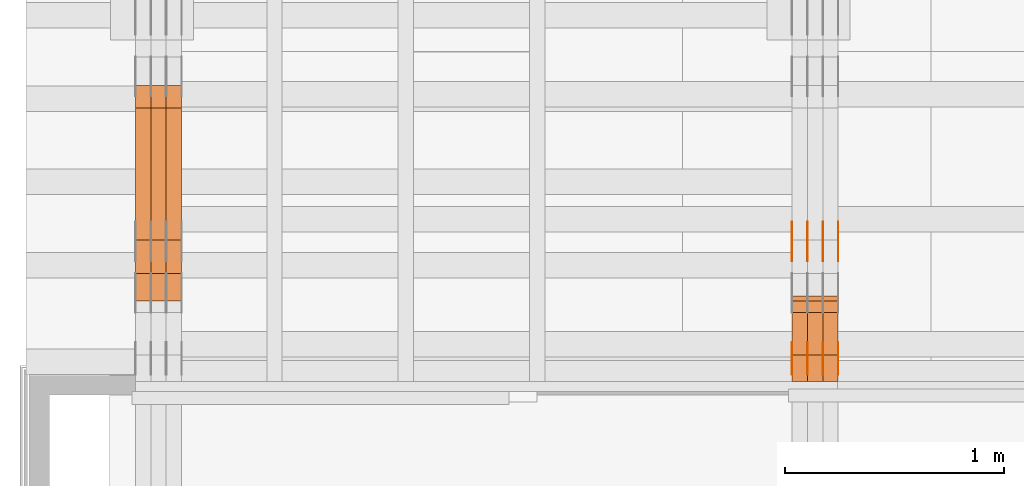
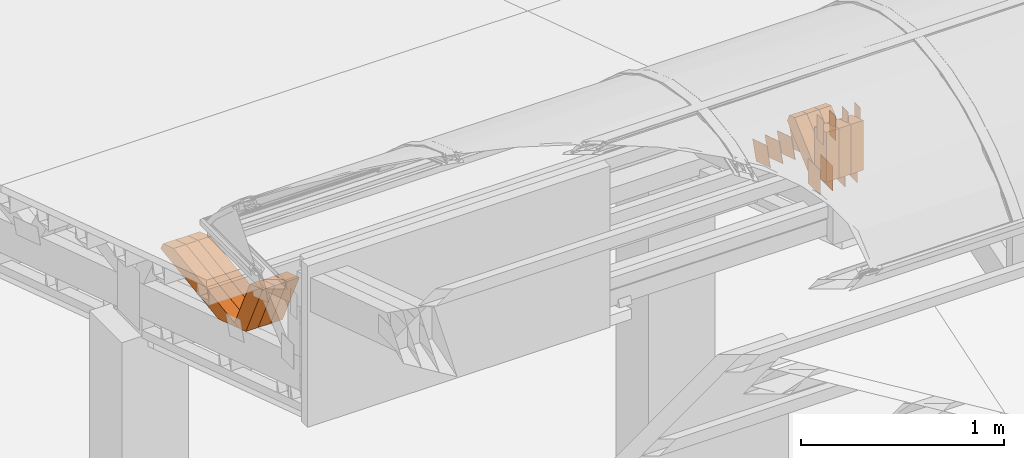
# One storey, part 83 of 385: 30 proxies.
"""IFC2X3 building model written with IfcOpenShell, lengths in millimetres."""

from ifc_helpers import new_model, entity, si_unit, converted_unit, derived_unit, direction, frame, origin, origin_2d_with_axis, place, context, subcontext, project, spatial, polyline, rectangle, outline, extrude, source, transform, mapped, material, type_object, type_shapes, element, save


model = new_model("IFC2X3")

# Units and contexts
model_context = context("Model", 3, precision=0.01, world=origin(), true_north=direction((6.12303176911189e-17, 1.0)))
body_context = subcontext(model_context, "Body", "Model", "MODEL_VIEW")
ifc_project = project(units=[si_unit("LENGTHUNIT", "METRE", prefix="MILLI"), si_unit("AREAUNIT", "SQUARE_METRE"), si_unit("VOLUMEUNIT", "CUBIC_METRE"), converted_unit("PLANEANGLEUNIT", "DEGREE", entity("IfcRatioMeasure", 0.0174532925199433), si_unit("PLANEANGLEUNIT", "RADIAN"), dimensions=[0, 0, 0, 0, 0, 0, 0]), si_unit("MASSUNIT", "GRAM", prefix="KILO"), derived_unit("MASSDENSITYUNIT", [(si_unit("MASSUNIT", "GRAM", prefix="KILO"), 1), (si_unit("LENGTHUNIT", "METRE"), -3)]), si_unit("TIMEUNIT", "SECOND"), si_unit("FREQUENCYUNIT", "HERTZ"), si_unit("THERMODYNAMICTEMPERATUREUNIT", "DEGREE_CELSIUS"), derived_unit("THERMALTRANSMITTANCEUNIT", [(si_unit("MASSUNIT", "GRAM", prefix="KILO"), 1), (si_unit("THERMODYNAMICTEMPERATUREUNIT", "KELVIN"), -1), (si_unit("TIMEUNIT", "SECOND"), -3)]), derived_unit("VOLUMETRICFLOWRATEUNIT", [(si_unit("LENGTHUNIT", "METRE"), 3), (si_unit("TIMEUNIT", "SECOND"), -1)]), si_unit("ELECTRICCURRENTUNIT", "AMPERE"), si_unit("ELECTRICVOLTAGEUNIT", "VOLT"), si_unit("POWERUNIT", "WATT"), si_unit("FORCEUNIT", "NEWTON", prefix="KILO"), si_unit("ILLUMINANCEUNIT", "LUX"), si_unit("LUMINOUSFLUXUNIT", "LUMEN"), si_unit("LUMINOUSINTENSITYUNIT", "CANDELA"), derived_unit("USERDEFINED", [(si_unit("MASSUNIT", "GRAM", prefix="KILO"), -1), (si_unit("LENGTHUNIT", "METRE"), -2), (si_unit("TIMEUNIT", "SECOND"), 3), (si_unit("LUMINOUSFLUXUNIT", "LUMEN"), 1)]), derived_unit("LINEARVELOCITYUNIT", [(si_unit("LENGTHUNIT", "METRE"), 1), (si_unit("TIMEUNIT", "SECOND"), -1)]), si_unit("PRESSUREUNIT", "PASCAL"), derived_unit("USERDEFINED", [(si_unit("LENGTHUNIT", "METRE"), -2), (si_unit("MASSUNIT", "GRAM", prefix="KILO"), 1), (si_unit("TIMEUNIT", "SECOND"), -2)])], contexts=[model_context])

# Site, building, storey
site_placement = place(None, origin())
site = spatial("IfcSite", under=ifc_project, at=site_placement, CompositionType="ELEMENT")
building_placement = place(site_placement, origin())
building = spatial("IfcBuilding", under=site, at=building_placement, CompositionType="ELEMENT")
storey_placement = place(building_placement, origin())
storey = spatial("IfcBuildingStorey", under=building, at=storey_placement, Name="Default", CompositionType="ELEMENT", Elevation=0.0)

# Proxies
ifc_material_1 = material(Name="IfcSurfaceStyle #67650")
building_element_proxy_type_1 = type_object("IfcBuildingElementProxyType", PredefinedType="NOTDEFINED", material=ifc_material_1)
shared_shape_1 = source(origin(), body_context, "Body", "SweptSolid", [
    extrude(rectangle(XDim=150.0, YDim=120.0, at=origin_2d_with_axis()), frame((75.0, 60.0, 0.0), z_axis=(0.0, 0.0, 1.0), x_axis=(-1.0, 0.0, 0.0)), (0.0, 0.0, 1.0), 1.3),
])
type_shapes(building_element_proxy_type_1, [shared_shape_1])
proxy_1_placement = place(building_placement, frame((3386.29999999999, 15840.0, 3652.70166015625), z_axis=(-1.0, 0.0, 0.0), x_axis=(0.0, 0.0, -1.0)))
element("IfcBuildingElementProxy", 1, at=proxy_1_placement, inside=storey, type_object=building_element_proxy_type_1, material=ifc_material_1, context=body_context, shape_type="MappedRepresentation", body=[
    mapped(shared_shape_1, transform((0.0, 0.0, 0.0), scale=1.0)),
])
ifc_material_2 = material(Name="IfcSurfaceStyle #67593")
building_element_proxy_type_2 = type_object("IfcBuildingElementProxyType", PredefinedType="NOTDEFINED", material=ifc_material_2)
shared_shape_2 = source(origin(), body_context, "Body", "SweptSolid", [
    extrude(rectangle(XDim=150.0, YDim=120.0, at=origin_2d_with_axis()), frame((75.0, 60.0, 0.0), z_axis=(0.0, 0.0, 1.0), x_axis=(-1.0, 0.0, 0.0)), (0.0, 0.0, 1.0), 1.3),
])
type_shapes(building_element_proxy_type_2, [shared_shape_2])
proxy_2_placement = place(building_placement, frame((3315.0, 15840.0, 3652.70166015625), z_axis=(-1.0, 0.0, 0.0), x_axis=(0.0, 0.0, -1.0)))
element("IfcBuildingElementProxy", 2, at=proxy_2_placement, inside=storey, type_object=building_element_proxy_type_2, material=ifc_material_2, context=body_context, shape_type="MappedRepresentation", body=[
    mapped(shared_shape_2, transform((0.0, 0.0, 0.0), scale=1.0)),
])
ifc_material_3 = material(Name="IfcSurfaceStyle #67536")
building_element_proxy_type_3 = type_object("IfcBuildingElementProxyType", PredefinedType="NOTDEFINED", material=ifc_material_3)
shared_shape_3 = source(origin(), body_context, "Body", "SweptSolid", [
    extrude(rectangle(XDim=150.0, YDim=120.0, at=origin_2d_with_axis()), frame((75.0, 60.0, 0.0), z_axis=(0.0, 0.0, 1.0), x_axis=(-1.0, 0.0, 0.0)), (0.0, 0.0, 1.0), 1.3),
])
type_shapes(building_element_proxy_type_3, [shared_shape_3])
proxy_3_placement = place(building_placement, frame((3316.29999999999, 15840.0, 3652.70166015625), z_axis=(-1.0, 0.0, 0.0), x_axis=(0.0, 0.0, -1.0)))
element("IfcBuildingElementProxy", 3, at=proxy_3_placement, inside=storey, type_object=building_element_proxy_type_3, material=ifc_material_3, context=body_context, shape_type="MappedRepresentation", body=[
    mapped(shared_shape_3, transform((0.0, 0.0, 0.0), scale=1.0)),
])
ifc_material_4 = material(Name="IfcSurfaceStyle #67479")
building_element_proxy_type_4 = type_object("IfcBuildingElementProxyType", PredefinedType="NOTDEFINED", material=ifc_material_4)
shared_shape_4 = source(origin(), body_context, "Body", "SweptSolid", [
    extrude(rectangle(XDim=150.0, YDim=120.0, at=origin_2d_with_axis()), frame((75.0, 60.0, 0.0), z_axis=(0.0, 0.0, 1.0), x_axis=(-1.0, 0.0, 0.0)), (0.0, 0.0, 1.0), 1.29999999999999),
])
type_shapes(building_element_proxy_type_4, [shared_shape_4])
proxy_4_placement = place(building_placement, frame((3245.0, 15840.0, 3652.70166015625), z_axis=(-1.0, 0.0, 0.0), x_axis=(0.0, 0.0, -1.0)))
element("IfcBuildingElementProxy", 4, at=proxy_4_placement, inside=storey, type_object=building_element_proxy_type_4, material=ifc_material_4, context=body_context, shape_type="MappedRepresentation", body=[
    mapped(shared_shape_4, transform((0.0, 0.0, 0.0), scale=1.0)),
])
ifc_material_5 = material(Name="IfcSurfaceStyle #67422")
building_element_proxy_type_5 = type_object("IfcBuildingElementProxyType", PredefinedType="NOTDEFINED", material=ifc_material_5)
shared_shape_5 = source(origin(), body_context, "Body", "SweptSolid", [
    extrude(rectangle(XDim=150.0, YDim=120.0, at=origin_2d_with_axis()), frame((75.0, 60.0, 0.0), z_axis=(0.0, 0.0, 1.0), x_axis=(-1.0, 0.0, 0.0)), (0.0, 0.0, 1.0), 1.29999999999999),
])
type_shapes(building_element_proxy_type_5, [shared_shape_5])
proxy_5_placement = place(building_placement, frame((3246.29999999999, 15840.0, 3652.70166015625), z_axis=(-1.0, 0.0, 0.0), x_axis=(0.0, 0.0, -1.0)))
element("IfcBuildingElementProxy", 5, at=proxy_5_placement, inside=storey, type_object=building_element_proxy_type_5, material=ifc_material_5, context=body_context, shape_type="MappedRepresentation", body=[
    mapped(shared_shape_5, transform((0.0, 0.0, 0.0), scale=1.0)),
])
ifc_material_6 = material(Name="IfcSurfaceStyle #67365")
building_element_proxy_type_6 = type_object("IfcBuildingElementProxyType", PredefinedType="NOTDEFINED", material=ifc_material_6)
shared_shape_6 = source(origin(), body_context, "Body", "SweptSolid", [
    extrude(rectangle(XDim=150.0, YDim=120.0, at=origin_2d_with_axis()), frame((75.0, 60.0, 0.0), z_axis=(0.0, 0.0, 1.0), x_axis=(-1.0, 0.0, 0.0)), (0.0, 0.0, 1.0), 1.29999999999999),
])
type_shapes(building_element_proxy_type_6, [shared_shape_6])
proxy_6_placement = place(building_placement, frame((3175.0, 15840.0, 3652.70166015625), z_axis=(-1.0, 0.0, 0.0), x_axis=(0.0, 0.0, -1.0)))
element("IfcBuildingElementProxy", 6, at=proxy_6_placement, inside=storey, type_object=building_element_proxy_type_6, material=ifc_material_6, context=body_context, shape_type="MappedRepresentation", body=[
    mapped(shared_shape_6, transform((0.0, 0.0, 0.0), scale=1.0)),
])
ifc_material_7 = material(Name="IfcSurfaceStyle #67308")
building_element_proxy_type_7 = type_object("IfcBuildingElementProxyType", PredefinedType="NOTDEFINED", material=ifc_material_7)
shared_shape_7 = source(origin(), body_context, "Body", "SweptSolid", [
    extrude(outline(polyline([(-74.9998605591118, -59.9999264677601), (74.9998754286171, -59.9999264677601), (74.9998605591118, 59.9999264677602), (-74.9998754286171, 59.9999264677602), (-74.9998605591118, -59.9999264677601)])), frame((74.9998754286171, 60.0000503992849, 0.0), z_axis=(0.0, 0.0, 1.0), x_axis=(-1.0, 0.0, 0.0)), (0.0, 0.0, 1.0), 1.3),
])
type_shapes(building_element_proxy_type_7, [shared_shape_7])
proxy_7_placement = place(building_placement, frame((3386.29999999999, 16352.8320303235, 3323.23212676408), z_axis=(-1.0, 0.0, 0.0), x_axis=(0.0, -0.951056516295124, 0.309016994375039)))
element("IfcBuildingElementProxy", 7, at=proxy_7_placement, inside=storey, type_object=building_element_proxy_type_7, material=ifc_material_7, context=body_context, shape_type="MappedRepresentation", body=[
    mapped(shared_shape_7, transform((0.0, 0.0, 0.0), scale=1.0)),
])
ifc_material_8 = material(Name="IfcSurfaceStyle #67251")
building_element_proxy_type_8 = type_object("IfcBuildingElementProxyType", PredefinedType="NOTDEFINED", material=ifc_material_8)
shared_shape_8 = source(origin(), body_context, "Body", "SweptSolid", [
    extrude(outline(polyline([(-74.9998605591118, -59.9999264677601), (74.9998754286171, -59.9999264677601), (74.9998605591118, 59.9999264677602), (-74.9998754286171, 59.9999264677602), (-74.9998605591118, -59.9999264677601)])), frame((74.9998754286171, 60.0000503992849, 0.0), z_axis=(0.0, 0.0, 1.0), x_axis=(-1.0, 0.0, 0.0)), (0.0, 0.0, 1.0), 1.3),
])
type_shapes(building_element_proxy_type_8, [shared_shape_8])
proxy_8_placement = place(building_placement, frame((3315.0, 16352.8320303235, 3323.23212676408), z_axis=(-1.0, 0.0, 0.0), x_axis=(0.0, -0.951056516295124, 0.309016994375039)))
element("IfcBuildingElementProxy", 8, at=proxy_8_placement, inside=storey, type_object=building_element_proxy_type_8, material=ifc_material_8, context=body_context, shape_type="MappedRepresentation", body=[
    mapped(shared_shape_8, transform((0.0, 0.0, 0.0), scale=1.0)),
])
ifc_material_9 = material(Name="IfcSurfaceStyle #67194")
building_element_proxy_type_9 = type_object("IfcBuildingElementProxyType", PredefinedType="NOTDEFINED", material=ifc_material_9)
shared_shape_9 = source(origin(), body_context, "Body", "SweptSolid", [
    extrude(outline(polyline([(-74.9998605591118, -59.9999264677601), (74.9998754286171, -59.9999264677601), (74.9998605591118, 59.9999264677602), (-74.9998754286171, 59.9999264677602), (-74.9998605591118, -59.9999264677601)])), frame((74.9998754286171, 60.0000503992849, 0.0), z_axis=(0.0, 0.0, 1.0), x_axis=(-1.0, 0.0, 0.0)), (0.0, 0.0, 1.0), 1.3),
])
type_shapes(building_element_proxy_type_9, [shared_shape_9])
proxy_9_placement = place(building_placement, frame((3316.29999999999, 16352.8320303235, 3323.23212676408), z_axis=(-1.0, 0.0, 0.0), x_axis=(0.0, -0.951056516295124, 0.309016994375039)))
element("IfcBuildingElementProxy", 9, at=proxy_9_placement, inside=storey, type_object=building_element_proxy_type_9, material=ifc_material_9, context=body_context, shape_type="MappedRepresentation", body=[
    mapped(shared_shape_9, transform((0.0, 0.0, 0.0), scale=1.0)),
])
ifc_material_10 = material(Name="IfcSurfaceStyle #67137")
building_element_proxy_type_10 = type_object("IfcBuildingElementProxyType", PredefinedType="NOTDEFINED", material=ifc_material_10)
shared_shape_10 = source(origin(), body_context, "Body", "SweptSolid", [
    extrude(outline(polyline([(-74.9998605591118, -59.9999264677601), (74.9998754286171, -59.9999264677601), (74.9998605591118, 59.9999264677602), (-74.9998754286171, 59.9999264677602), (-74.9998605591118, -59.9999264677601)])), frame((74.9998754286171, 60.0000503992849, 0.0), z_axis=(0.0, 0.0, 1.0), x_axis=(-1.0, 0.0, 0.0)), (0.0, 0.0, 1.0), 1.29999999999999),
])
type_shapes(building_element_proxy_type_10, [shared_shape_10])
proxy_10_placement = place(building_placement, frame((3245.0, 16352.8320303235, 3323.23212676408), z_axis=(-1.0, 0.0, 0.0), x_axis=(0.0, -0.951056516295124, 0.309016994375039)))
element("IfcBuildingElementProxy", 10, at=proxy_10_placement, inside=storey, type_object=building_element_proxy_type_10, material=ifc_material_10, context=body_context, shape_type="MappedRepresentation", body=[
    mapped(shared_shape_10, transform((0.0, 0.0, 0.0), scale=1.0)),
])
ifc_material_11 = material(Name="IfcSurfaceStyle #67080")
building_element_proxy_type_11 = type_object("IfcBuildingElementProxyType", PredefinedType="NOTDEFINED", material=ifc_material_11)
shared_shape_11 = source(origin(), body_context, "Body", "SweptSolid", [
    extrude(outline(polyline([(-74.9998605591118, -59.9999264677601), (74.9998754286171, -59.9999264677601), (74.9998605591118, 59.9999264677602), (-74.9998754286171, 59.9999264677602), (-74.9998605591118, -59.9999264677601)])), frame((74.9998754286171, 60.0000503992849, 0.0), z_axis=(0.0, 0.0, 1.0), x_axis=(-1.0, 0.0, 0.0)), (0.0, 0.0, 1.0), 1.29999999999999),
])
type_shapes(building_element_proxy_type_11, [shared_shape_11])
proxy_11_placement = place(building_placement, frame((3246.29999999999, 16352.8320303235, 3323.23212676408), z_axis=(-1.0, 0.0, 0.0), x_axis=(0.0, -0.951056516295124, 0.309016994375039)))
element("IfcBuildingElementProxy", 11, at=proxy_11_placement, inside=storey, type_object=building_element_proxy_type_11, material=ifc_material_11, context=body_context, shape_type="MappedRepresentation", body=[
    mapped(shared_shape_11, transform((0.0, 0.0, 0.0), scale=1.0)),
])
ifc_material_12 = material(Name="IfcSurfaceStyle #67023")
building_element_proxy_type_12 = type_object("IfcBuildingElementProxyType", PredefinedType="NOTDEFINED", material=ifc_material_12)
shared_shape_12 = source(origin(), body_context, "Body", "SweptSolid", [
    extrude(outline(polyline([(-74.9998605591118, -59.9999264677601), (74.9998754286171, -59.9999264677601), (74.9998605591118, 59.9999264677602), (-74.9998754286171, 59.9999264677602), (-74.9998605591118, -59.9999264677601)])), frame((74.9998754286171, 60.0000503992849, 0.0), z_axis=(0.0, 0.0, 1.0), x_axis=(-1.0, 0.0, 0.0)), (0.0, 0.0, 1.0), 1.29999999999999),
])
type_shapes(building_element_proxy_type_12, [shared_shape_12])
proxy_12_placement = place(building_placement, frame((3175.0, 16352.8320303235, 3323.23212676408), z_axis=(-1.0, 0.0, 0.0), x_axis=(0.0, -0.951056516295124, 0.309016994375039)))
element("IfcBuildingElementProxy", 12, at=proxy_12_placement, inside=storey, type_object=building_element_proxy_type_12, material=ifc_material_12, context=body_context, shape_type="MappedRepresentation", body=[
    mapped(shared_shape_12, transform((0.0, 0.0, 0.0), scale=1.0)),
])
ifc_material_13 = material(Name="IfcSurfaceStyle #62178")
building_element_proxy_type_13 = type_object("IfcBuildingElementProxyType", PredefinedType="NOTDEFINED", material=ifc_material_13)
shared_shape_13 = source(origin(), body_context, "Body", "SweptSolid", [
    extrude(rectangle(XDim=150.0, YDim=60.0, at=origin_2d_with_axis()), frame((75.0000705696311, 30.0, 0.0), z_axis=(0.0, 0.0, 1.0), x_axis=(-1.0, 0.0, 0.0)), (0.0, 0.0, 1.0), 1.3),
])
type_shapes(building_element_proxy_type_13, [shared_shape_13])
proxy_13_placement = place(building_placement, frame((3386.29999999999, 15750.0, 3972.59919166338), z_axis=(-1.0, 0.0, 0.0), x_axis=(0.0, 0.0, -1.0)))
element("IfcBuildingElementProxy", 13, at=proxy_13_placement, inside=storey, type_object=building_element_proxy_type_13, material=ifc_material_13, context=body_context, shape_type="MappedRepresentation", body=[
    mapped(shared_shape_13, transform((0.0, 0.0, 0.0), scale=1.0)),
])
ifc_material_14 = material(Name="IfcSurfaceStyle #62121")
building_element_proxy_type_14 = type_object("IfcBuildingElementProxyType", PredefinedType="NOTDEFINED", material=ifc_material_14)
shared_shape_14 = source(origin(), body_context, "Body", "SweptSolid", [
    extrude(rectangle(XDim=150.0, YDim=60.0, at=origin_2d_with_axis()), frame((75.0000705696311, 30.0, 0.0), z_axis=(0.0, 0.0, 1.0), x_axis=(-1.0, 0.0, 0.0)), (0.0, 0.0, 1.0), 1.3),
])
type_shapes(building_element_proxy_type_14, [shared_shape_14])
proxy_14_placement = place(building_placement, frame((3315.0, 15750.0, 3972.59919166338), z_axis=(-1.0, 0.0, 0.0), x_axis=(0.0, 0.0, -1.0)))
element("IfcBuildingElementProxy", 14, at=proxy_14_placement, inside=storey, type_object=building_element_proxy_type_14, material=ifc_material_14, context=body_context, shape_type="MappedRepresentation", body=[
    mapped(shared_shape_14, transform((0.0, 0.0, 0.0), scale=1.0)),
])
ifc_material_15 = material(Name="IfcSurfaceStyle #62064")
building_element_proxy_type_15 = type_object("IfcBuildingElementProxyType", PredefinedType="NOTDEFINED", material=ifc_material_15)
shared_shape_15 = source(origin(), body_context, "Body", "SweptSolid", [
    extrude(rectangle(XDim=150.0, YDim=60.0, at=origin_2d_with_axis()), frame((75.0000705696311, 30.0, 0.0), z_axis=(0.0, 0.0, 1.0), x_axis=(-1.0, 0.0, 0.0)), (0.0, 0.0, 1.0), 1.3),
])
type_shapes(building_element_proxy_type_15, [shared_shape_15])
proxy_15_placement = place(building_placement, frame((3316.29999999999, 15750.0, 3972.59919166338), z_axis=(-1.0, 0.0, 0.0), x_axis=(0.0, 0.0, -1.0)))
element("IfcBuildingElementProxy", 15, at=proxy_15_placement, inside=storey, type_object=building_element_proxy_type_15, material=ifc_material_15, context=body_context, shape_type="MappedRepresentation", body=[
    mapped(shared_shape_15, transform((0.0, 0.0, 0.0), scale=1.0)),
])
ifc_material_16 = material(Name="IfcSurfaceStyle #62007")
building_element_proxy_type_16 = type_object("IfcBuildingElementProxyType", PredefinedType="NOTDEFINED", material=ifc_material_16)
shared_shape_16 = source(origin(), body_context, "Body", "SweptSolid", [
    extrude(rectangle(XDim=150.0, YDim=60.0, at=origin_2d_with_axis()), frame((75.0000705696311, 30.0, 0.0), z_axis=(0.0, 0.0, 1.0), x_axis=(-1.0, 0.0, 0.0)), (0.0, 0.0, 1.0), 1.29999999999999),
])
type_shapes(building_element_proxy_type_16, [shared_shape_16])
proxy_16_placement = place(building_placement, frame((3245.0, 15750.0, 3972.59919166338), z_axis=(-1.0, 0.0, 0.0), x_axis=(0.0, 0.0, -1.0)))
element("IfcBuildingElementProxy", 16, at=proxy_16_placement, inside=storey, type_object=building_element_proxy_type_16, material=ifc_material_16, context=body_context, shape_type="MappedRepresentation", body=[
    mapped(shared_shape_16, transform((0.0, 0.0, 0.0), scale=1.0)),
])
ifc_material_17 = material(Name="IfcSurfaceStyle #61950")
building_element_proxy_type_17 = type_object("IfcBuildingElementProxyType", PredefinedType="NOTDEFINED", material=ifc_material_17)
shared_shape_17 = source(origin(), body_context, "Body", "SweptSolid", [
    extrude(rectangle(XDim=150.0, YDim=60.0, at=origin_2d_with_axis()), frame((75.0000705696311, 30.0, 0.0), z_axis=(0.0, 0.0, 1.0), x_axis=(-1.0, 0.0, 0.0)), (0.0, 0.0, 1.0), 1.29999999999999),
])
type_shapes(building_element_proxy_type_17, [shared_shape_17])
proxy_17_placement = place(building_placement, frame((3246.29999999999, 15750.0, 3972.59919166338), z_axis=(-1.0, 0.0, 0.0), x_axis=(0.0, 0.0, -1.0)))
element("IfcBuildingElementProxy", 17, at=proxy_17_placement, inside=storey, type_object=building_element_proxy_type_17, material=ifc_material_17, context=body_context, shape_type="MappedRepresentation", body=[
    mapped(shared_shape_17, transform((0.0, 0.0, 0.0), scale=1.0)),
])
ifc_material_18 = material(Name="IfcSurfaceStyle #61893")
building_element_proxy_type_18 = type_object("IfcBuildingElementProxyType", PredefinedType="NOTDEFINED", material=ifc_material_18)
shared_shape_18 = source(origin(), body_context, "Body", "SweptSolid", [
    extrude(rectangle(XDim=150.0, YDim=60.0, at=origin_2d_with_axis()), frame((75.0000705696311, 30.0, 0.0), z_axis=(0.0, 0.0, 1.0), x_axis=(-1.0, 0.0, 0.0)), (0.0, 0.0, 1.0), 1.29999999999999),
])
type_shapes(building_element_proxy_type_18, [shared_shape_18])
proxy_18_placement = place(building_placement, frame((3175.0, 15750.0, 3972.59919166338), z_axis=(-1.0, 0.0, 0.0), x_axis=(0.0, 0.0, -1.0)))
element("IfcBuildingElementProxy", 18, at=proxy_18_placement, inside=storey, type_object=building_element_proxy_type_18, material=ifc_material_18, context=body_context, shape_type="MappedRepresentation", body=[
    mapped(shared_shape_18, transform((0.0, 0.0, 0.0), scale=1.0)),
])
ifc_material_19 = material(Name="IfcSurfaceStyle #52809")
building_element_proxy_type_19 = type_object("IfcBuildingElementProxyType", Name="T1-W50 52807", PredefinedType="NOTDEFINED", material=ifc_material_19)
shared_shape_19 = source(origin(), body_context, "Body", "SweptSolid", [
    extrude(outline(polyline([(-128.56619634284, -47.4999385885712), (133.151257249084, -47.4999385885712), (161.172800006526, -0.000129729183733609), (147.291467726413, 47.500068317755), (-142.513973767368, 47.500068317755), (-170.535354871815, -0.000129729183754689), (-128.56619634284, -47.4999385885712)])), frame((161.17310141218, 47.5001898716564, 0.0), z_axis=(0.0, 0.0, 1.0), x_axis=(-1.0, 0.0, 0.0)), (0.0, 0.0, 1.0), 70.0),
])
type_shapes(building_element_proxy_type_19, [shared_shape_19])
proxy_19_placement = place(building_placement, frame((3385.0, 16060.0297689714, 3761.73994820667), z_axis=(-1.0, 0.0, 0.0), x_axis=(0.0, -0.749388407538668, -0.662130662820156)))
element("IfcBuildingElementProxy", 19, at=proxy_19_placement, inside=storey, type_object=building_element_proxy_type_19, material=ifc_material_19, Name="T1-W50", context=body_context, shape_type="MappedRepresentation", body=[
    mapped(shared_shape_19, transform((0.0, 0.0, 0.0), scale=1.0)),
])
ifc_material_20 = material(Name="IfcSurfaceStyle #52734")
building_element_proxy_type_20 = type_object("IfcBuildingElementProxyType", Name="T1-W50 52732", PredefinedType="NOTDEFINED", material=ifc_material_20)
shared_shape_20 = source(origin(), body_context, "Body", "SweptSolid", [
    extrude(outline(polyline([(-128.56619634284, -47.4999385885712), (133.151257249084, -47.4999385885712), (161.172800006526, -0.000129729183733609), (147.291467726413, 47.500068317755), (-142.513973767368, 47.500068317755), (-170.535354871815, -0.000129729183754689), (-128.56619634284, -47.4999385885712)])), frame((161.17310141218, 47.5001898716564, 0.0), z_axis=(0.0, 0.0, 1.0), x_axis=(-1.0, 0.0, 0.0)), (0.0, 0.0, 1.0), 70.0),
])
type_shapes(building_element_proxy_type_20, [shared_shape_20])
proxy_20_placement = place(building_placement, frame((3315.0, 16060.0297689714, 3761.73994820667), z_axis=(-1.0, 0.0, 0.0), x_axis=(0.0, -0.749388407538668, -0.662130662820156)))
element("IfcBuildingElementProxy", 20, at=proxy_20_placement, inside=storey, type_object=building_element_proxy_type_20, material=ifc_material_20, Name="T1-W50", context=body_context, shape_type="MappedRepresentation", body=[
    mapped(shared_shape_20, transform((0.0, 0.0, 0.0), scale=1.0)),
])
ifc_material_21 = material(Name="IfcSurfaceStyle #52659")
building_element_proxy_type_21 = type_object("IfcBuildingElementProxyType", Name="T1-W50 52657", PredefinedType="NOTDEFINED", material=ifc_material_21)
shared_shape_21 = source(origin(), body_context, "Body", "SweptSolid", [
    extrude(outline(polyline([(-128.56619634284, -47.4999385885712), (133.151257249084, -47.4999385885712), (161.172800006526, -0.000129729183733609), (147.291467726413, 47.500068317755), (-142.513973767368, 47.500068317755), (-170.535354871815, -0.000129729183754689), (-128.56619634284, -47.4999385885712)])), frame((161.17310141218, 47.5001898716564, 0.0), z_axis=(0.0, 0.0, 1.0), x_axis=(-1.0, 0.0, 0.0)), (0.0, 0.0, 1.0), 70.0),
])
type_shapes(building_element_proxy_type_21, [shared_shape_21])
proxy_21_placement = place(building_placement, frame((3245.0, 16060.0297689714, 3761.73994820667), z_axis=(-1.0, 0.0, 0.0), x_axis=(0.0, -0.749388407538668, -0.662130662820156)))
element("IfcBuildingElementProxy", 21, at=proxy_21_placement, inside=storey, type_object=building_element_proxy_type_21, material=ifc_material_21, Name="T1-W50", context=body_context, shape_type="MappedRepresentation", body=[
    mapped(shared_shape_21, transform((0.0, 0.0, 0.0), scale=1.0)),
])
ifc_material_22 = material(Name="IfcSurfaceStyle #52413")
building_element_proxy_type_22 = type_object("IfcBuildingElementProxyType", Name="T1-W2 52411", PredefinedType="NOTDEFINED", material=ifc_material_22)
shared_shape_22 = source(origin(), body_context, "Body", "SweptSolid", [
    extrude(outline(polyline([(-130.705993652344, -60.0), (169.696350097656, -60.0), (130.706115722656, 60.0), (-169.696472167969, 60.0), (-130.705993652344, -60.0)])), frame((169.696429629256, 60.0, 0.0), z_axis=(0.0, 0.0, 1.0), x_axis=(-1.0, 0.0, 0.0)), (0.0, 0.0, 1.0), 70.0),
])
type_shapes(building_element_proxy_type_22, [shared_shape_22])
proxy_22_placement = place(building_placement, frame((3385.0, 15660.0, 3577.70158062465), z_axis=(-1.0, 0.0, 0.0), x_axis=(0.0, 0.0, 1.0)))
element("IfcBuildingElementProxy", 22, at=proxy_22_placement, inside=storey, type_object=building_element_proxy_type_22, material=ifc_material_22, Name="T1-W2", context=body_context, shape_type="MappedRepresentation", body=[
    mapped(shared_shape_22, transform((0.0, 0.0, 0.0), scale=1.0)),
])
ifc_material_23 = material(Name="IfcSurfaceStyle #52356")
building_element_proxy_type_23 = type_object("IfcBuildingElementProxyType", Name="T1-W2 52354", PredefinedType="NOTDEFINED", material=ifc_material_23)
shared_shape_23 = source(origin(), body_context, "Body", "SweptSolid", [
    extrude(outline(polyline([(-130.705993652344, -60.0), (169.696350097656, -60.0), (130.706115722656, 60.0), (-169.696472167969, 60.0), (-130.705993652344, -60.0)])), frame((169.696429629256, 60.0, 0.0), z_axis=(0.0, 0.0, 1.0), x_axis=(-1.0, 0.0, 0.0)), (0.0, 0.0, 1.0), 70.0),
])
type_shapes(building_element_proxy_type_23, [shared_shape_23])
proxy_23_placement = place(building_placement, frame((3315.0, 15660.0, 3577.70158062465), z_axis=(-1.0, 0.0, 0.0), x_axis=(0.0, 0.0, 1.0)))
element("IfcBuildingElementProxy", 23, at=proxy_23_placement, inside=storey, type_object=building_element_proxy_type_23, material=ifc_material_23, Name="T1-W2", context=body_context, shape_type="MappedRepresentation", body=[
    mapped(shared_shape_23, transform((0.0, 0.0, 0.0), scale=1.0)),
])
ifc_material_24 = material(Name="IfcSurfaceStyle #52299")
building_element_proxy_type_24 = type_object("IfcBuildingElementProxyType", Name="T1-W2 52297", PredefinedType="NOTDEFINED", material=ifc_material_24)
shared_shape_24 = source(origin(), body_context, "Body", "SweptSolid", [
    extrude(outline(polyline([(-130.705993652344, -60.0), (169.696350097656, -60.0), (130.706115722656, 60.0), (-169.696472167969, 60.0), (-130.705993652344, -60.0)])), frame((169.696429629256, 60.0, 0.0), z_axis=(0.0, 0.0, 1.0), x_axis=(-1.0, 0.0, 0.0)), (0.0, 0.0, 1.0), 70.0),
])
type_shapes(building_element_proxy_type_24, [shared_shape_24])
proxy_24_placement = place(building_placement, frame((3245.0, 15660.0, 3577.70158062465), z_axis=(-1.0, 0.0, 0.0), x_axis=(0.0, 0.0, 1.0)))
element("IfcBuildingElementProxy", 24, at=proxy_24_placement, inside=storey, type_object=building_element_proxy_type_24, material=ifc_material_24, Name="T1-W2", context=body_context, shape_type="MappedRepresentation", body=[
    mapped(shared_shape_24, transform((0.0, 0.0, 0.0), scale=1.0)),
])
ifc_material_25 = material(Name="IfcSurfaceStyle #17810")
building_element_proxy_type_25 = type_object("IfcBuildingElementProxyType", Name="T1-W44 17808", PredefinedType="NOTDEFINED", material=ifc_material_25)
shared_shape_25 = source(origin(), body_context, "Body", "SweptSolid", [
    extrude(outline(polyline([(-184.551057772692, -47.4997984945814), (177.527112951531, -47.4997984945814), (162.630077773546, -0.000452497529500495), (118.068221667048, 47.5000247433462), (-273.674354619433, 47.5000247433462), (-184.551057772692, -47.4997984945814)])), frame((177.527112951531, 47.5002721629815, 0.0), z_axis=(0.0, 0.0, 1.0), x_axis=(-1.0, 0.0, 0.0)), (0.0, 0.0, 1.0), 70.0),
])
type_shapes(building_element_proxy_type_25, [shared_shape_25])
proxy_25_placement = place(building_placement, frame((385.0, 16220.4899216004, 3388.98238154171), z_axis=(-1.0, 0.0, 0.0), x_axis=(0.0, -0.425335045192995, 0.905035965766374)))
element("IfcBuildingElementProxy", 25, at=proxy_25_placement, inside=storey, type_object=building_element_proxy_type_25, material=ifc_material_25, Name="T1-W44", context=body_context, shape_type="MappedRepresentation", body=[
    mapped(shared_shape_25, transform((0.0, 0.0, 0.0), scale=1.0)),
])
ifc_material_26 = material(Name="IfcSurfaceStyle #17744")
building_element_proxy_type_26 = type_object("IfcBuildingElementProxyType", Name="T1-W44 17742", PredefinedType="NOTDEFINED", material=ifc_material_26)
shared_shape_26 = source(origin(), body_context, "Body", "SweptSolid", [
    extrude(outline(polyline([(-184.551057772692, -47.4997984945814), (177.527112951531, -47.4997984945814), (162.630077773546, -0.000452497529500495), (118.068221667048, 47.5000247433462), (-273.674354619433, 47.5000247433462), (-184.551057772692, -47.4997984945814)])), frame((177.527112951531, 47.5002721629815, 0.0), z_axis=(0.0, 0.0, 1.0), x_axis=(-1.0, 0.0, 0.0)), (0.0, 0.0, 1.0), 70.0),
])
type_shapes(building_element_proxy_type_26, [shared_shape_26])
proxy_26_placement = place(building_placement, frame((315.0, 16220.4899216004, 3388.98238154171), z_axis=(-1.0, 0.0, 0.0), x_axis=(0.0, -0.425335045192995, 0.905035965766374)))
element("IfcBuildingElementProxy", 26, at=proxy_26_placement, inside=storey, type_object=building_element_proxy_type_26, material=ifc_material_26, Name="T1-W44", context=body_context, shape_type="MappedRepresentation", body=[
    mapped(shared_shape_26, transform((0.0, 0.0, 0.0), scale=1.0)),
])
ifc_material_27 = material(Name="IfcSurfaceStyle #17678")
building_element_proxy_type_27 = type_object("IfcBuildingElementProxyType", Name="T1-W44 17676", PredefinedType="NOTDEFINED", material=ifc_material_27)
shared_shape_27 = source(origin(), body_context, "Body", "SweptSolid", [
    extrude(outline(polyline([(-184.551057772692, -47.4997984945814), (177.527112951531, -47.4997984945814), (162.630077773546, -0.000452497529500495), (118.068221667048, 47.5000247433462), (-273.674354619433, 47.5000247433462), (-184.551057772692, -47.4997984945814)])), frame((177.527112951531, 47.5002721629815, 0.0), z_axis=(0.0, 0.0, 1.0), x_axis=(-1.0, 0.0, 0.0)), (0.0, 0.0, 1.0), 70.0),
])
type_shapes(building_element_proxy_type_27, [shared_shape_27])
proxy_27_placement = place(building_placement, frame((245.0, 16220.4899216004, 3388.98238154171), z_axis=(-1.0, 0.0, 0.0), x_axis=(0.0, -0.425335045192995, 0.905035965766374)))
element("IfcBuildingElementProxy", 27, at=proxy_27_placement, inside=storey, type_object=building_element_proxy_type_27, material=ifc_material_27, Name="T1-W44", context=body_context, shape_type="MappedRepresentation", body=[
    mapped(shared_shape_27, transform((0.0, 0.0, 0.0), scale=1.0)),
])
ifc_material_28 = material(Name="IfcSurfaceStyle #17414")
building_element_proxy_type_28 = type_object("IfcBuildingElementProxyType", Name="T1-W8 17412", PredefinedType="NOTDEFINED", material=ifc_material_28)
shared_shape_28 = source(origin(), body_context, "Body", "SweptSolid", [
    extrude(outline(polyline([(-476.725263324644, -47.5001051695965), (180.672765845439, -47.5001051695965), (279.11020091716, -1.03605560390907e-06), (296.793624402619, 47.5001056876243), (-279.851327840575, 47.5001056876243), (-476.725263324644, -47.5001051695965)])), frame((296.793624402619, 47.5001056876243, 0.0), z_axis=(0.0, 0.0, 1.0), x_axis=(-1.0, 0.0, 0.0)), (0.0, 0.0, 1.0), 70.0),
])
type_shapes(building_element_proxy_type_28, [shared_shape_28])
proxy_28_placement = place(building_placement, frame((385.0, 17036.40625, 3432.97192382813), z_axis=(-1.0, 0.0, 0.0), x_axis=(0.0, -0.990844046556832, -0.135011389900564)))
element("IfcBuildingElementProxy", 28, at=proxy_28_placement, inside=storey, type_object=building_element_proxy_type_28, material=ifc_material_28, Name="T1-W8", context=body_context, shape_type="MappedRepresentation", body=[
    mapped(shared_shape_28, transform((0.0, 0.0, 0.0), scale=1.0)),
])
ifc_material_29 = material(Name="IfcSurfaceStyle #17348")
building_element_proxy_type_29 = type_object("IfcBuildingElementProxyType", Name="T1-W8 17346", PredefinedType="NOTDEFINED", material=ifc_material_29)
shared_shape_29 = source(origin(), body_context, "Body", "SweptSolid", [
    extrude(outline(polyline([(-476.725263324644, -47.5001051695965), (180.672765845439, -47.5001051695965), (279.11020091716, -1.03605560390907e-06), (296.793624402619, 47.5001056876243), (-279.851327840575, 47.5001056876243), (-476.725263324644, -47.5001051695965)])), frame((296.793624402619, 47.5001056876243, 0.0), z_axis=(0.0, 0.0, 1.0), x_axis=(-1.0, 0.0, 0.0)), (0.0, 0.0, 1.0), 70.0),
])
type_shapes(building_element_proxy_type_29, [shared_shape_29])
proxy_29_placement = place(building_placement, frame((315.0, 17036.40625, 3432.97192382813), z_axis=(-1.0, 0.0, 0.0), x_axis=(0.0, -0.990844046556832, -0.135011389900564)))
element("IfcBuildingElementProxy", 29, at=proxy_29_placement, inside=storey, type_object=building_element_proxy_type_29, material=ifc_material_29, Name="T1-W8", context=body_context, shape_type="MappedRepresentation", body=[
    mapped(shared_shape_29, transform((0.0, 0.0, 0.0), scale=1.0)),
])
ifc_material_30 = material(Name="IfcSurfaceStyle #17282")
building_element_proxy_type_30 = type_object("IfcBuildingElementProxyType", Name="T1-W8 17280", PredefinedType="NOTDEFINED", material=ifc_material_30)
shared_shape_30 = source(origin(), body_context, "Body", "SweptSolid", [
    extrude(outline(polyline([(-476.725263324644, -47.5001051695965), (180.672765845439, -47.5001051695965), (279.11020091716, -1.03605560390907e-06), (296.793624402619, 47.5001056876243), (-279.851327840575, 47.5001056876243), (-476.725263324644, -47.5001051695965)])), frame((296.793624402619, 47.5001056876243, 0.0), z_axis=(0.0, 0.0, 1.0), x_axis=(-1.0, 0.0, 0.0)), (0.0, 0.0, 1.0), 70.0),
])
type_shapes(building_element_proxy_type_30, [shared_shape_30])
proxy_30_placement = place(building_placement, frame((245.0, 17036.40625, 3432.97192382813), z_axis=(-1.0, 0.0, 0.0), x_axis=(0.0, -0.990844046556832, -0.135011389900564)))
element("IfcBuildingElementProxy", 30, at=proxy_30_placement, inside=storey, type_object=building_element_proxy_type_30, material=ifc_material_30, Name="T1-W8", context=body_context, shape_type="MappedRepresentation", body=[
    mapped(shared_shape_30, transform((0.0, 0.0, 0.0), scale=1.0)),
])

save(model, "model.ifc")
